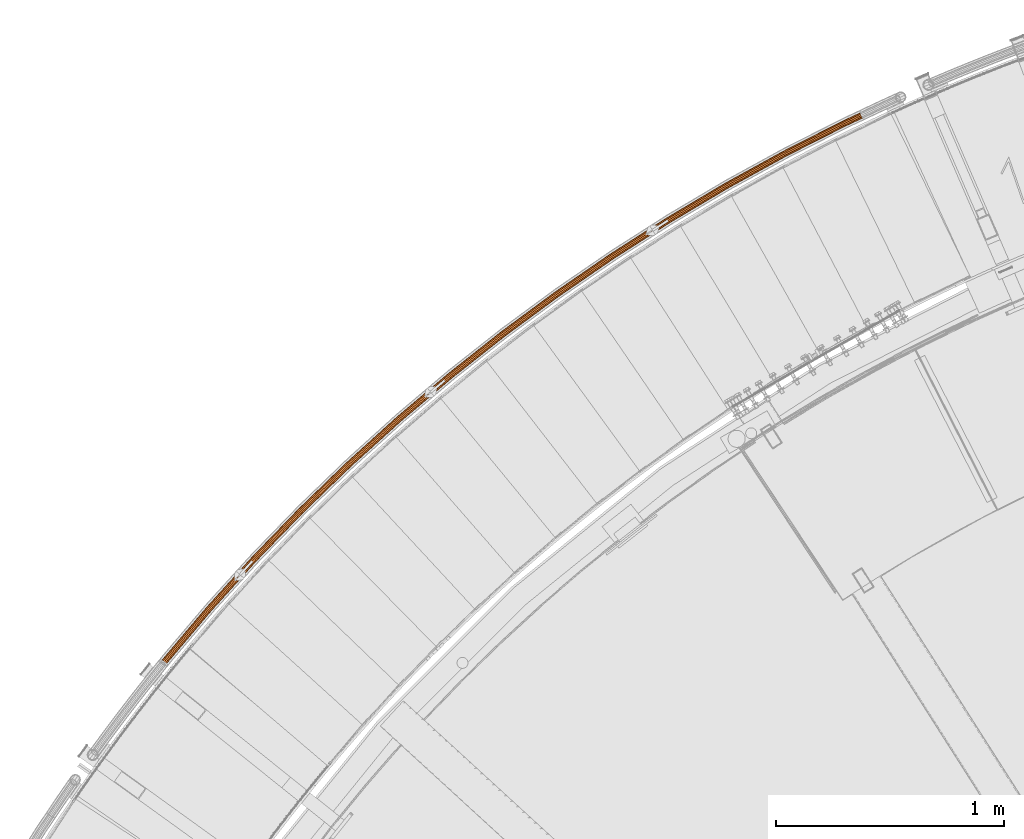
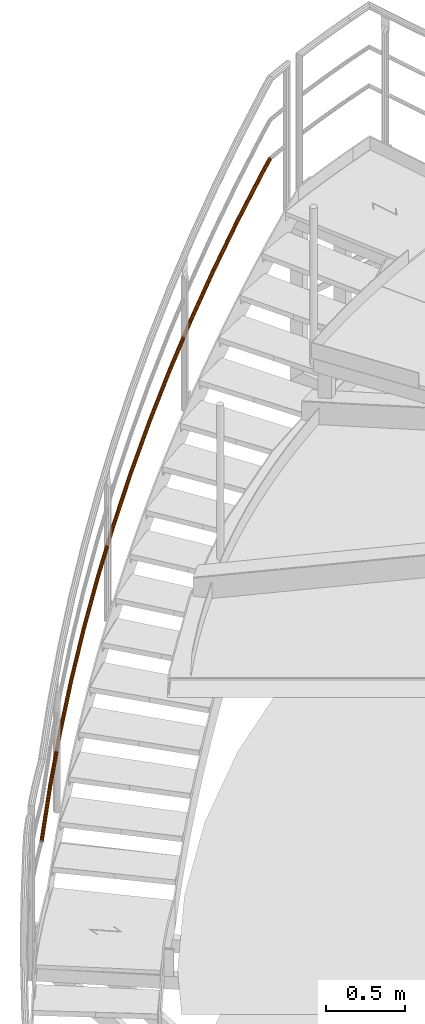
# One storey, part 34 of 126: 1 proxy.
"""IFC2X3 building model written with IfcOpenShell, lengths in millimetres."""

from ifc_helpers import new_model, si_unit, origin, origin_with_axes, place, context, project, spatial, faceted_brep, material, element, save


model = new_model("IFC2X3")

# Units and contexts
context_of_model_1 = context(None, 3, precision=0.1, world=origin())
context_of_model_2 = context(None, 3, precision=0.1, world=origin())
ifc_project = project(units=[si_unit("LENGTHUNIT", "METRE", prefix="MILLI"), si_unit("AREAUNIT", "SQUARE_METRE", prefix="CENTI"), si_unit("VOLUMEUNIT", "CUBIC_METRE", prefix="CENTI"), si_unit("MASSUNIT", "GRAM", prefix="KILO")], contexts=[context_of_model_1, context_of_model_2])

# Site, building, storey
site_placement = place(None, origin_with_axes())
site = spatial("IfcSite", under=ifc_project, at=site_placement, CompositionType="ELEMENT")
building_placement = place(site_placement, origin_with_axes())
building = spatial("IfcBuilding", under=site, at=building_placement, CompositionType="ELEMENT")
storey_placement = place(building_placement, origin_with_axes())
storey = spatial("IfcBuildingStorey", under=building, at=storey_placement, CompositionType="ELEMENT")

# Proxy
ifc_material = material(Name="S235JRG2")
proxy_placement = place(storey_placement, origin_with_axes())
element("IfcBuildingElementProxy", 1, at=proxy_placement, inside=storey, material=ifc_material, context=context_of_model_2, shape_type="Brep", body=[
    faceted_brep([(1138.8066, 13610.681, 8790.2317), (1134.2211, 13615.725, 8788.8115), (1124.8424, 13603.861, 8778.1524), (1129.9924, 13599.531, 8780.2142), (1132.1521, 13621.046, 8784.8264), (1121.7807, 13607.926, 8773.0392), (1133.1539, 13625.219, 8779.3441), (1121.6279, 13610.638, 8766.2446), (1136.9581, 13627.126, 8773.8336), (1124.4248, 13611.271, 8759.5893), (1142.5454, 13626.255, 8769.7715), (1129.4221, 13609.654, 8754.8565), (1148.4187, 13622.841, 8768.2461), (1135.2806, 13606.221, 8753.3144), (1153.0042, 13617.797, 8769.6662), (1140.4306, 13601.891, 8755.3761), (1155.0732, 13612.476, 8773.6513), (1143.4922, 13597.826, 8760.4893), (1154.0714, 13608.303, 8779.1336), (1143.6451, 13595.113, 8767.2839), (1150.2671, 13606.396, 8784.6441), (1140.8482, 13594.481, 8773.9392), (1144.6798, 13607.267, 8788.7063), (1135.8509, 13596.098, 8778.6721), (1139.5212, 13611.585, 8788.597), (1144.5211, 13608.678, 8787.2985), (1135.3729, 13597.106, 8776.9014), (1130.3856, 13600.029, 8778.2142), (1149.2776, 13607.937, 8783.8404), (1139.6271, 13595.729, 8772.8723), (1152.5162, 13609.56, 8779.1493), (1142.0081, 13596.268, 8767.2066), (1153.369, 13613.113, 8774.4822), (1141.878, 13598.577, 8761.4224), (1151.6077, 13617.643, 8771.0897), (1139.2717, 13602.038, 8757.0695), (1147.704, 13621.937, 8769.8807), (1134.8874, 13605.723, 8755.3144), (1142.7041, 13624.843, 8771.1793), (1129.9, 13608.646, 8756.6272), (1137.9476, 13625.584, 8774.6374), (1125.6459, 13610.023, 8760.6562), (1134.7091, 13623.961, 8779.3285), (1123.2649, 13609.484, 8766.3219), (1133.8562, 13620.409, 8783.9956), (1123.395, 13607.175, 8772.1061), (1135.6176, 13615.879, 8787.3881), (1126.0013, 13603.714, 8776.459), (1328.8909, 13835.767, 8997.8784), (1324.4755, 13840.96, 8996.4583), (1322.5845, 13846.347, 8992.4731), (1323.7245, 13850.484, 8986.9908), (1327.5901, 13852.263, 8981.4803), (1333.1453, 13851.208, 8977.4182), (1338.9018, 13847.6, 8975.8928), (1343.3171, 13842.407, 8977.3129), (1345.2082, 13837.02, 8981.298), (1344.0683, 13832.882, 8986.7803), (1340.2028, 13831.103, 8992.2908), (1334.6475, 13832.159, 8996.353), (1329.6352, 13836.646, 8996.2438), (1334.5358, 13833.575, 8994.9452), (1339.265, 13832.676, 8991.487), (1342.5557, 13834.191, 8986.7959), (1343.5261, 13837.713, 8982.1289), (1341.9163, 13842.299, 8978.7364), (1338.1575, 13846.72, 8977.5275), (1333.257, 13849.791, 8978.826), (1328.5278, 13850.69, 8982.2841), (1325.2371, 13849.176, 8986.9752), (1324.2666, 13845.654, 8991.6423), (1325.8764, 13841.067, 8995.0348), (1526.3504, 14054.411, 9205.5251), (1522.1101, 14059.748, 9204.105), (1520.3991, 14065.195, 9200.1198), (1521.676, 14069.292, 9194.6375), (1525.5986, 14070.942, 9189.1271), (1531.1157, 14069.702, 9185.0649), (1536.7491, 14065.905, 9183.5396), (1540.9894, 14060.568, 9184.9597), (1542.7004, 14055.121, 9188.9447), (1541.4236, 14051.024, 9194.427), (1537.5011, 14049.374, 9199.9375), (1531.984, 14050.614, 9203.9997), (1527.1236, 14055.265, 9203.8905), (1531.9194, 14052.033, 9202.592), (1536.6162, 14050.978, 9199.1338), (1539.9554, 14052.382, 9194.4427), (1541.0423, 14055.87, 9189.7756), (1539.5857, 14060.507, 9186.3831), (1535.976, 14065.05, 9185.1742), (1531.1802, 14068.283, 9186.4727), (1526.4835, 14069.338, 9189.9308), (1523.1442, 14067.934, 9194.6219), (1522.0572, 14064.446, 9199.289), (1523.5138, 14059.809, 9202.6816), (1730.967, 14266.372, 9413.1719), (1726.9064, 14271.847, 9411.7517), (1725.3774, 14277.348, 9407.7666), (1726.7897, 14281.401, 9402.2843), (1730.7649, 14282.919, 9396.7738), (1736.2378, 14281.497, 9392.7117), (1741.7419, 14277.514, 9391.1863), (1745.8025, 14272.039, 9392.6064), (1747.3315, 14266.539, 9396.5915), (1745.9193, 14262.486, 9402.0738), (1741.9442, 14260.968, 9407.5843), (1736.4712, 14262.39, 9411.6465), (1731.7681, 14267.201, 9411.5373), (1736.4539, 14263.811, 9410.2387), (1741.113, 14262.6, 9406.7805), (1744.497, 14263.892, 9402.0894), (1745.6993, 14267.342, 9397.4224), (1744.3976, 14272.025, 9394.0299), (1740.9408, 14276.686, 9392.821), (1736.2551, 14280.076, 9394.1195), (1731.5961, 14281.287, 9397.5776), (1728.212, 14279.994, 9402.2686), (1727.0097, 14276.544, 9406.9357), (1728.3113, 14271.862, 9410.3283), (1942.5146, 14471.416, 9620.8186), (1938.6382, 14477.023, 9619.3985), (1937.2929, 14482.572, 9615.4133), (1938.8391, 14486.575, 9609.931), (1942.8625, 14487.961, 9604.4206), (1948.2851, 14486.357, 9600.3584), (1953.6539, 14482.194, 9598.8331), (1957.5302, 14476.588, 9600.2532), (1958.8756, 14471.039, 9604.2382), (1957.3295, 14467.036, 9609.7205), (1953.3061, 14465.65, 9615.231), (1947.8835, 14467.254, 9619.2932), (1943.3428, 14472.218, 9619.184), (1947.9133, 14468.674, 9617.8854), (1952.5296, 14467.309, 9614.4273), (1955.9547, 14468.488, 9609.7362), (1957.271, 14471.897, 9605.0691), (1956.1256, 14476.62, 9601.6766), (1952.8257, 14481.393, 9600.4677), (1948.2552, 14484.937, 9601.7662), (1943.639, 14486.302, 9605.2243), (1940.2138, 14485.123, 9609.9154), (1938.8975, 14481.715, 9614.5825), (1940.0428, 14476.991, 9617.9751), (2160.7596, 14669.317, 9828.4654), (2157.0716, 14675.05, 9827.0452), (2155.9114, 14680.64, 9823.0601), (2157.5898, 14684.59, 9817.5778), (2161.6571, 14685.841, 9812.0673), (2167.0234, 14684.058, 9808.0052), (2172.2508, 14679.719, 9806.4798), (2175.9387, 14673.986, 9807.8999), (2177.099, 14668.396, 9811.885), (2175.4206, 14664.446, 9817.3672), (2171.3534, 14663.195, 9822.8778), (2165.9871, 14664.978, 9826.94), (2161.6139, 14670.091, 9826.8308), (2166.0641, 14666.397, 9825.5322), (2170.6325, 14664.879, 9822.074), (2174.0949, 14665.944, 9817.3829), (2175.5237, 14669.307, 9812.7159), (2174.536, 14674.066, 9809.3234), (2171.3964, 14678.946, 9808.1144), (2166.9463, 14682.639, 9809.413), (2162.378, 14684.157, 9812.8711), (2158.9155, 14683.092, 9817.5621), (2157.4867, 14679.73, 9822.2292), (2158.4744, 14674.971, 9825.6218), (2385.4607, 14859.856, 10036.112), (2381.9653, 14865.708, 10034.692), (2380.9915, 14871.334, 10030.707), (2382.8003, 14875.225, 10025.225), (2386.9069, 14876.341, 10019.714), (2392.2109, 14874.38, 10015.652), (2397.2913, 14869.87, 10014.127), (2400.7866, 14864.018, 10015.547), (2401.7605, 14858.392, 10019.532), (2399.9518, 14854.501, 10025.014), (2395.8453, 14853.385, 10030.525), (2390.5411, 14855.345, 10034.587), (2386.3403, 14860.6, 10034.478), (2390.6653, 14856.761, 10033.179), (2395.1807, 14855.092, 10029.721), (2398.6766, 14856.041, 10025.03), (2400.2163, 14859.354, 10020.363), (2399.3873, 14864.144, 10016.97), (2396.4117, 14869.125, 10015.761), (2392.0868, 14872.965, 10017.06), (2387.5714, 14874.634, 10020.518), (2384.0755, 14873.684, 10025.209), (2382.5357, 14870.371, 10029.876), (2383.3646, 14865.582, 10033.269), (2616.3698, 15042.822, 10243.759), (2613.0708, 15048.787, 10242.339), (2612.2845, 15054.442, 10238.354), (2614.2216, 15058.271, 10232.871), (2618.363, 15059.249, 10227.361), (2623.599, 15057.114, 10223.299), (2628.5267, 15052.437, 10221.773), (2631.8256, 15046.472, 10223.193), (2632.612, 15040.817, 10227.179), (2630.675, 15036.988, 10232.661), (2626.5336, 15036.01, 10238.171), (2621.2976, 15038.145, 10242.234), (2617.2737, 15043.537, 10242.124), (2621.4687, 15039.555, 10240.826), (2625.9261, 15037.737, 10237.368), (2629.4517, 15038.57, 10232.676), (2631.1006, 15041.83, 10228.009), (2630.4312, 15046.644, 10224.617), (2627.6228, 15051.722, 10223.408), (2623.4279, 15055.704, 10224.707), (2618.9705, 15057.522, 10228.165), (2615.4449, 15056.689, 10232.856), (2613.7959, 15053.429, 10237.523), (2614.4652, 15048.615, 10240.915), (2853.2318, 15218.013, 10451.406), (2850.1329, 15224.084, 10449.986), (2849.535, 15229.762, 10446.0), (2851.5983, 15233.525, 10440.518), (2855.7699, 15234.365, 10435.008), (2860.932, 15232.057, 10430.945), (2865.7015, 15227.219, 10429.42), (2868.8004, 15221.148, 10430.84), (2869.3984, 15215.47, 10434.825), (2867.3352, 15211.707, 10440.308), (2863.1636, 15210.867, 10445.818), (2858.0014, 15213.175, 10449.88), (2854.159, 15218.697, 10449.771), (2858.2193, 15214.579, 10448.472), (2862.6139, 15212.614, 10445.014), (2866.1652, 15213.329, 10440.323), (2867.9216, 15216.532, 10435.656), (2867.4125, 15221.366, 10432.264), (2864.7744, 15226.535, 10431.055), (2860.7141, 15230.653, 10432.353), (2856.3196, 15232.618, 10435.811), (2852.7683, 15231.903, 10440.502), (2851.0118, 15228.7, 10445.17), (2851.5208, 15223.866, 10448.562), (3095.7851, 15385.236, 10659.052), (3092.8896, 15391.407, 10657.632), (3092.4807, 15397.101, 10653.647), (3094.6679, 15400.794, 10648.165), (3098.8652, 15401.495, 10642.654), (3103.9477, 15399.016, 10638.592), (3108.5538, 15394.022, 10637.067), (3111.4493, 15387.852, 10638.487), (3111.8582, 15382.157, 10642.472), (3109.6711, 15378.464, 10647.954), (3105.4739, 15377.763, 10653.465), (3100.3913, 15380.242, 10657.527), (3096.7344, 15385.889, 10657.418), (3100.6557, 15381.638, 10656.119), (3104.9825, 15379.528, 10652.661), (3108.5556, 15380.125, 10647.97), (3110.4175, 15383.268, 10643.303), (3110.0694, 15388.116, 10639.91), (3107.6045, 15393.369, 10638.701), (3103.6833, 15397.62, 10640.0), (3099.3565, 15399.73, 10643.458), (3095.7834, 15399.134, 10648.149), (3093.9214, 15395.99, 10652.816), (3094.2695, 15391.142, 10656.209), (3343.7616, 15544.306, 10866.699), (3341.0729, 15550.569, 10865.279), (3340.8534, 15556.275, 10861.294), (3343.1621, 15559.892, 10855.812), (3347.3803, 15560.453, 10850.301), (3352.3777, 15557.807, 10846.239), (3356.8153, 15552.663, 10844.714), (3359.5041, 15546.399, 10846.134), (3359.7236, 15540.694, 10850.119), (3357.4149, 15537.076, 10855.601), (3353.1968, 15536.515, 10861.112), (3348.1993, 15539.161, 10865.174), (3344.7322, 15544.927, 10865.065), (3348.51, 15540.548, 10863.766), (3352.7643, 15538.295, 10860.308), (3356.3552, 15538.773, 10855.617), (3358.3206, 15541.853, 10850.95), (3358.1337, 15546.709, 10847.557), (3355.8448, 15552.042, 10846.348), (3352.067, 15556.421, 10847.647), (3347.8127, 15558.673, 10851.105), (3344.2218, 15558.196, 10855.796), (3342.2564, 15555.116, 10860.463), (3342.4432, 15550.259, 10863.856), (3596.8875, 15695.047, 11074.346), (3594.4084, 15701.396, 11072.926), (3594.3787, 15707.106, 11068.941), (3596.8063, 15710.645, 11063.458), (3601.0408, 15711.065, 11057.948), (3605.9475, 15708.254, 11053.886), (3610.2117, 15702.966, 11052.36), (3612.6908, 15696.616, 11053.78), (3612.7206, 15690.907, 11057.766), (3610.293, 15687.368, 11063.248), (3606.0586, 15686.947, 11068.758), (3601.1518, 15689.758, 11072.821), (3597.8782, 15695.635, 11072.711), (3601.5083, 15691.133, 11071.413), (3605.6855, 15688.74, 11067.955), (3609.2903, 15689.098, 11063.263), (3611.3569, 15692.111, 11058.596), (3611.3315, 15696.971, 11055.204), (3609.2211, 15702.377, 11053.995), (3605.591, 15706.879, 11055.294), (3601.4139, 15709.272, 11058.752), (3597.809, 15708.914, 11063.443), (3595.7424, 15705.901, 11068.11), (3595.7677, 15701.041, 11071.502), (3854.8831, 15837.292, 11281.993), (3852.6163, 15843.721, 11280.573), (3852.7764, 15849.428, 11276.587), (3855.3203, 15852.884, 11271.105), (3859.5664, 15853.164, 11265.594), (3864.377, 15850.192, 11261.532), (3868.4631, 15844.764, 11260.007), (3870.7298, 15838.336, 11261.427), (3870.5699, 15832.629, 11265.412), (3868.026, 15829.172, 11270.895), (3863.7799, 15828.893, 11276.405), (3858.9693, 15831.865, 11280.467), (3855.8928, 15837.848, 11280.358), (3859.3713, 15833.227, 11279.059), (3863.4666, 15830.697, 11275.601), (3867.0813, 15830.935, 11270.91), (3869.2469, 15833.878, 11266.243), (3869.3831, 15838.736, 11262.851), (3867.4534, 15844.209, 11261.642), (3863.975, 15848.829, 11262.94), (3859.8797, 15851.359, 11266.398), (3856.265, 15851.121, 11271.089), (3854.0993, 15848.179, 11275.757), (3853.9631, 15843.32, 11279.149), (4117.4634, 15970.886, 11489.639), (4115.4115, 15977.386, 11488.219), (4115.7611, 15983.085, 11484.234), (4118.4185, 15986.454, 11478.752), (4122.6716, 15986.593, 11473.241), (4127.3807, 15983.462, 11469.179), (4131.2842, 15977.902, 11467.654), (4133.336, 15971.402, 11469.074), (4132.9865, 15965.703, 11473.059), (4130.3292, 15962.333, 11478.541), (4126.0761, 15962.195, 11484.052), (4121.3669, 15965.325, 11488.114), (4118.4909, 15971.407, 11488.005), (4121.814, 15966.674, 11486.706), (4125.823, 15964.009, 11483.248), (4129.4436, 15964.127, 11478.557), (4131.7058, 15966.995, 11473.89), (4132.0034, 15971.847, 11470.497), (4130.2566, 15977.38, 11469.288), (4126.9336, 15982.114, 11470.587), (4122.9247, 15984.779, 11474.045), (4119.304, 15984.661, 11478.736), (4117.0418, 15981.792, 11483.403), (4116.7442, 15976.941, 11486.796), (4197.2202, 16008.181, 11551.696), (4194.9624, 16014.574, 11550.065), (4194.3236, 16019.78, 11545.268), (4195.4744, 16022.405, 11538.591), (4198.1066, 16021.747, 11531.821), (4201.5151, 16017.981, 11526.772), (4204.7873, 16012.116, 11524.796), (4207.0464, 16005.722, 11526.424), (4207.6866, 16000.513, 11531.22), (4206.5358, 15997.886, 11537.9), (4203.9024, 15998.545, 11544.673), (4200.4925, 16002.313, 11549.722), (4197.7831, 16008.472, 11549.696), (4200.5688, 16003.478, 11548.015), (4203.4716, 16000.27, 11543.717), (4205.7134, 15999.709, 11537.951), (4206.693, 16001.946, 11532.265), (4206.1481, 16006.38, 11528.182), (4204.225, 16011.823, 11526.796), (4201.4394, 16016.816, 11528.478), (4198.5376, 16020.022, 11532.776), (4196.2968, 16020.582, 11538.539), (4195.3171, 16018.347, 11544.224), (4195.861, 16013.915, 11548.308)], [[[0, 1, 2, 3]], [[1, 4, 5, 2]], [[4, 6, 7, 5]], [[6, 8, 9, 7]], [[8, 10, 11, 9]], [[10, 12, 13, 11]], [[12, 14, 15, 13]], [[14, 16, 17, 15]], [[16, 18, 19, 17]], [[18, 20, 21, 19]], [[20, 22, 23, 21]], [[0, 3, 23, 22]], [[24, 25, 26, 27]], [[25, 28, 29, 26]], [[28, 30, 31, 29]], [[30, 32, 33, 31]], [[32, 34, 35, 33]], [[34, 36, 37, 35]], [[36, 38, 39, 37]], [[38, 40, 41, 39]], [[40, 42, 43, 41]], [[42, 44, 45, 43]], [[44, 46, 47, 45]], [[24, 27, 47, 46]], [[0, 48, 49, 1]], [[1, 49, 50, 4]], [[4, 50, 51, 6]], [[6, 51, 52, 8]], [[8, 52, 53, 10]], [[10, 53, 54, 12]], [[12, 54, 55, 14]], [[14, 55, 56, 16]], [[16, 56, 57, 18]], [[18, 57, 58, 20]], [[20, 58, 59, 22]], [[22, 59, 48, 0]], [[24, 60, 61, 25]], [[25, 61, 62, 28]], [[28, 62, 63, 30]], [[30, 63, 64, 32]], [[32, 64, 65, 34]], [[34, 65, 66, 36]], [[36, 66, 67, 38]], [[38, 67, 68, 40]], [[40, 68, 69, 42]], [[42, 69, 70, 44]], [[44, 70, 71, 46]], [[46, 71, 60, 24]], [[48, 72, 73, 49]], [[49, 73, 74, 50]], [[50, 74, 75, 51]], [[51, 75, 76, 52]], [[52, 76, 77, 53]], [[53, 77, 78, 54]], [[54, 78, 79, 55]], [[55, 79, 80, 56]], [[56, 80, 81, 57]], [[57, 81, 82, 58]], [[58, 82, 83, 59]], [[59, 83, 72, 48]], [[60, 84, 85, 61]], [[61, 85, 86, 62]], [[62, 86, 87, 63]], [[63, 87, 88, 64]], [[64, 88, 89, 65]], [[65, 89, 90, 66]], [[66, 90, 91, 67]], [[67, 91, 92, 68]], [[68, 92, 93, 69]], [[69, 93, 94, 70]], [[70, 94, 95, 71]], [[71, 95, 84, 60]], [[72, 96, 97, 73]], [[73, 97, 98, 74]], [[74, 98, 99, 75]], [[75, 99, 100, 76]], [[76, 100, 101, 77]], [[77, 101, 102, 78]], [[78, 102, 103, 79]], [[79, 103, 104, 80]], [[80, 104, 105, 81]], [[81, 105, 106, 82]], [[82, 106, 107, 83]], [[83, 107, 96, 72]], [[84, 108, 109, 85]], [[85, 109, 110, 86]], [[86, 110, 111, 87]], [[87, 111, 112, 88]], [[88, 112, 113, 89]], [[89, 113, 114, 90]], [[90, 114, 115, 91]], [[91, 115, 116, 92]], [[92, 116, 117, 93]], [[93, 117, 118, 94]], [[94, 118, 119, 95]], [[95, 119, 108, 84]], [[96, 120, 121, 97]], [[97, 121, 122, 98]], [[98, 122, 123, 99]], [[99, 123, 124, 100]], [[100, 124, 125, 101]], [[101, 125, 126, 102]], [[102, 126, 127, 103]], [[103, 127, 128, 104]], [[104, 128, 129, 105]], [[105, 129, 130, 106]], [[106, 130, 131, 107]], [[107, 131, 120, 96]], [[108, 132, 133, 109]], [[109, 133, 134, 110]], [[110, 134, 135, 111]], [[111, 135, 136, 112]], [[112, 136, 137, 113]], [[113, 137, 138, 114]], [[114, 138, 139, 115]], [[115, 139, 140, 116]], [[116, 140, 141, 117]], [[117, 141, 142, 118]], [[118, 142, 143, 119]], [[119, 143, 132, 108]], [[120, 144, 145, 121]], [[121, 145, 146, 122]], [[122, 146, 147, 123]], [[123, 147, 148, 124]], [[124, 148, 149, 125]], [[125, 149, 150, 126]], [[126, 150, 151, 127]], [[127, 151, 152, 128]], [[128, 152, 153, 129]], [[129, 153, 154, 130]], [[130, 154, 155, 131]], [[131, 155, 144, 120]], [[132, 156, 157, 133]], [[133, 157, 158, 134]], [[134, 158, 159, 135]], [[135, 159, 160, 136]], [[136, 160, 161, 137]], [[137, 161, 162, 138]], [[138, 162, 163, 139]], [[139, 163, 164, 140]], [[140, 164, 165, 141]], [[141, 165, 166, 142]], [[142, 166, 167, 143]], [[143, 167, 156, 132]], [[144, 168, 169, 145]], [[145, 169, 170, 146]], [[146, 170, 171, 147]], [[147, 171, 172, 148]], [[148, 172, 173, 149]], [[149, 173, 174, 150]], [[150, 174, 175, 151]], [[151, 175, 176, 152]], [[152, 176, 177, 153]], [[153, 177, 178, 154]], [[154, 178, 179, 155]], [[155, 179, 168, 144]], [[156, 180, 181, 157]], [[157, 181, 182, 158]], [[158, 182, 183, 159]], [[159, 183, 184, 160]], [[160, 184, 185, 161]], [[161, 185, 186, 162]], [[162, 186, 187, 163]], [[163, 187, 188, 164]], [[164, 188, 189, 165]], [[165, 189, 190, 166]], [[166, 190, 191, 167]], [[167, 191, 180, 156]], [[168, 192, 193, 169]], [[169, 193, 194, 170]], [[170, 194, 195, 171]], [[171, 195, 196, 172]], [[172, 196, 197, 173]], [[173, 197, 198, 174]], [[174, 198, 199, 175]], [[175, 199, 200, 176]], [[176, 200, 201, 177]], [[177, 201, 202, 178]], [[178, 202, 203, 179]], [[179, 203, 192, 168]], [[180, 204, 205, 181]], [[181, 205, 206, 182]], [[182, 206, 207, 183]], [[183, 207, 208, 184]], [[184, 208, 209, 185]], [[185, 209, 210, 186]], [[186, 210, 211, 187]], [[187, 211, 212, 188]], [[188, 212, 213, 189]], [[189, 213, 214, 190]], [[190, 214, 215, 191]], [[191, 215, 204, 180]], [[192, 216, 217, 193]], [[193, 217, 218, 194]], [[194, 218, 219, 195]], [[195, 219, 220, 196]], [[196, 220, 221, 197]], [[197, 221, 222, 198]], [[198, 222, 223, 199]], [[199, 223, 224, 200]], [[200, 224, 225, 201]], [[201, 225, 226, 202]], [[202, 226, 227, 203]], [[203, 227, 216, 192]], [[204, 228, 229, 205]], [[205, 229, 230, 206]], [[206, 230, 231, 207]], [[207, 231, 232, 208]], [[208, 232, 233, 209]], [[209, 233, 234, 210]], [[210, 234, 235, 211]], [[211, 235, 236, 212]], [[212, 236, 237, 213]], [[213, 237, 238, 214]], [[214, 238, 239, 215]], [[215, 239, 228, 204]], [[216, 240, 241, 217]], [[217, 241, 242, 218]], [[218, 242, 243, 219]], [[219, 243, 244, 220]], [[220, 244, 245, 221]], [[221, 245, 246, 222]], [[222, 246, 247, 223]], [[223, 247, 248, 224]], [[224, 248, 249, 225]], [[225, 249, 250, 226]], [[226, 250, 251, 227]], [[227, 251, 240, 216]], [[228, 252, 253, 229]], [[229, 253, 254, 230]], [[230, 254, 255, 231]], [[231, 255, 256, 232]], [[232, 256, 257, 233]], [[233, 257, 258, 234]], [[234, 258, 259, 235]], [[235, 259, 260, 236]], [[236, 260, 261, 237]], [[237, 261, 262, 238]], [[238, 262, 263, 239]], [[239, 263, 252, 228]], [[240, 264, 265, 241]], [[241, 265, 266, 242]], [[242, 266, 267, 243]], [[243, 267, 268, 244]], [[244, 268, 269, 245]], [[245, 269, 270, 246]], [[246, 270, 271, 247]], [[247, 271, 272, 248]], [[248, 272, 273, 249]], [[249, 273, 274, 250]], [[250, 274, 275, 251]], [[251, 275, 264, 240]], [[252, 276, 277, 253]], [[253, 277, 278, 254]], [[254, 278, 279, 255]], [[255, 279, 280, 256]], [[256, 280, 281, 257]], [[257, 281, 282, 258]], [[258, 282, 283, 259]], [[259, 283, 284, 260]], [[260, 284, 285, 261]], [[261, 285, 286, 262]], [[262, 286, 287, 263]], [[263, 287, 276, 252]], [[264, 288, 289, 265]], [[265, 289, 290, 266]], [[266, 290, 291, 267]], [[267, 291, 292, 268]], [[268, 292, 293, 269]], [[269, 293, 294, 270]], [[270, 294, 295, 271]], [[271, 295, 296, 272]], [[272, 296, 297, 273]], [[273, 297, 298, 274]], [[274, 298, 299, 275]], [[275, 299, 288, 264]], [[276, 300, 301, 277]], [[277, 301, 302, 278]], [[278, 302, 303, 279]], [[279, 303, 304, 280]], [[280, 304, 305, 281]], [[281, 305, 306, 282]], [[282, 306, 307, 283]], [[283, 307, 308, 284]], [[284, 308, 309, 285]], [[285, 309, 310, 286]], [[286, 310, 311, 287]], [[287, 311, 300, 276]], [[288, 312, 313, 289]], [[289, 313, 314, 290]], [[290, 314, 315, 291]], [[291, 315, 316, 292]], [[292, 316, 317, 293]], [[293, 317, 318, 294]], [[294, 318, 319, 295]], [[295, 319, 320, 296]], [[296, 320, 321, 297]], [[297, 321, 322, 298]], [[298, 322, 323, 299]], [[299, 323, 312, 288]], [[300, 324, 325, 301]], [[301, 325, 326, 302]], [[302, 326, 327, 303]], [[303, 327, 328, 304]], [[304, 328, 329, 305]], [[305, 329, 330, 306]], [[306, 330, 331, 307]], [[307, 331, 332, 308]], [[308, 332, 333, 309]], [[309, 333, 334, 310]], [[310, 334, 335, 311]], [[311, 335, 324, 300]], [[312, 336, 337, 313]], [[313, 337, 338, 314]], [[314, 338, 339, 315]], [[315, 339, 340, 316]], [[316, 340, 341, 317]], [[317, 341, 342, 318]], [[318, 342, 343, 319]], [[319, 343, 344, 320]], [[320, 344, 345, 321]], [[321, 345, 346, 322]], [[322, 346, 347, 323]], [[323, 347, 336, 312]], [[324, 348, 349, 325]], [[325, 349, 350, 326]], [[326, 350, 351, 327]], [[327, 351, 352, 328]], [[328, 352, 353, 329]], [[329, 353, 354, 330]], [[330, 354, 355, 331]], [[331, 355, 356, 332]], [[332, 356, 357, 333]], [[333, 357, 358, 334]], [[334, 358, 359, 335]], [[335, 359, 348, 324]], [[336, 360, 361, 337]], [[337, 361, 362, 338]], [[338, 362, 363, 339]], [[339, 363, 364, 340]], [[340, 364, 365, 341]], [[341, 365, 366, 342]], [[342, 366, 367, 343]], [[343, 367, 368, 344]], [[344, 368, 369, 345]], [[345, 369, 370, 346]], [[346, 370, 371, 347]], [[336, 347, 371, 360]], [[348, 372, 373, 349]], [[349, 373, 374, 350]], [[350, 374, 375, 351]], [[351, 375, 376, 352]], [[352, 376, 377, 353]], [[353, 377, 378, 354]], [[354, 378, 379, 355]], [[355, 379, 380, 356]], [[356, 380, 381, 357]], [[357, 381, 382, 358]], [[358, 382, 383, 359]], [[348, 359, 383, 372]], [[7, 9, 11, 13, 15, 17, 19, 21, 23, 3, 2, 5], [26, 29, 31, 33, 35, 37, 39, 41, 43, 45, 47, 27]], [[360, 371, 370, 369, 368, 367, 366, 365, 364, 363, 362, 361], [372, 383, 382, 381, 380, 379, 378, 377, 376, 375, 374, 373]]]),
])

save(model, "model.ifc")
